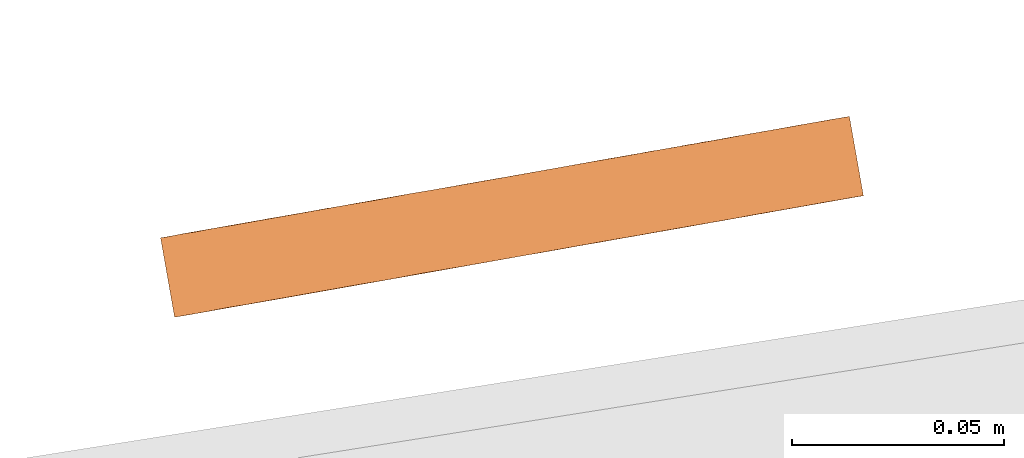
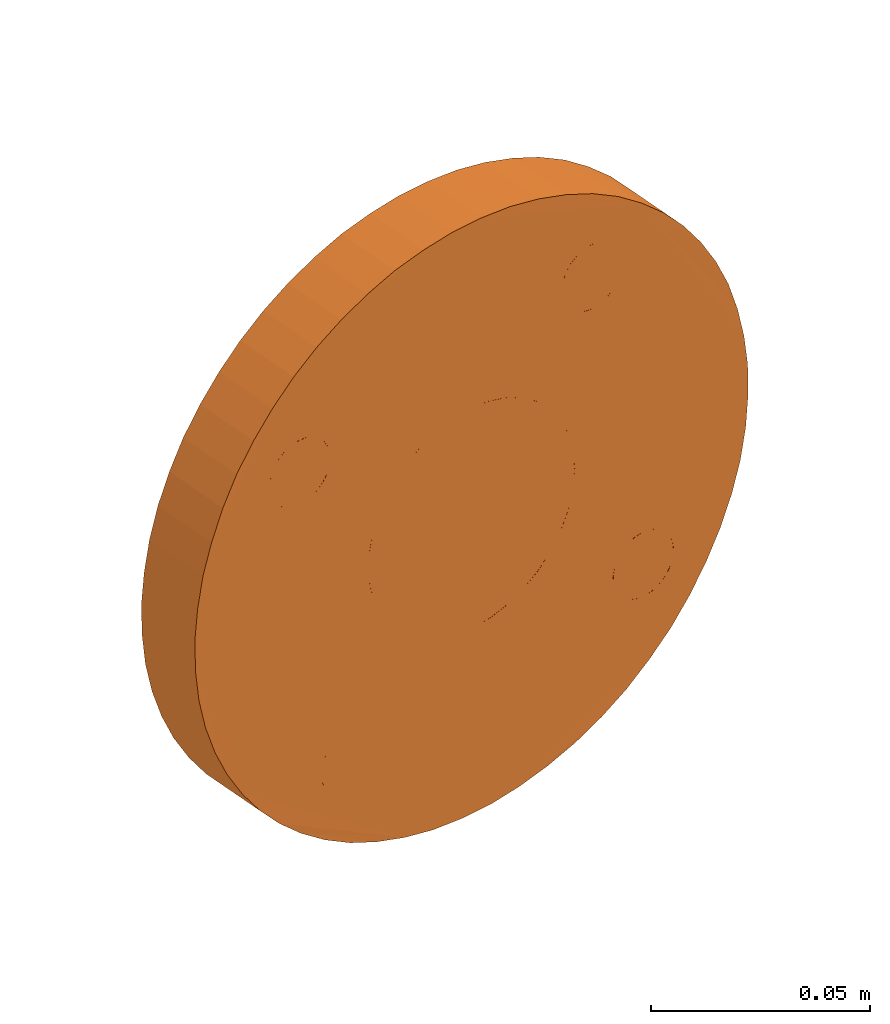
# One storey, part 89 of 126: 1 proxy.
"""IFC2X3 building model written with IfcOpenShell, lengths in millimetres."""

from ifc_helpers import new_model, si_unit, origin, origin_with_axes, place, context, project, spatial, faceted_brep, material, element, save


model = new_model("IFC2X3")

# Units and contexts
context_of_model_1 = context(None, 3, precision=0.1, world=origin())
context_of_model_2 = context(None, 3, precision=0.1, world=origin())
ifc_project = project(units=[si_unit("LENGTHUNIT", "METRE", prefix="MILLI"), si_unit("AREAUNIT", "SQUARE_METRE", prefix="CENTI"), si_unit("VOLUMEUNIT", "CUBIC_METRE", prefix="CENTI"), si_unit("MASSUNIT", "GRAM", prefix="KILO")], contexts=[context_of_model_1, context_of_model_2])

# Site, building, storey
site_placement = place(None, origin_with_axes())
site = spatial("IfcSite", under=ifc_project, at=site_placement, CompositionType="ELEMENT")
building_placement = place(site_placement, origin_with_axes())
building = spatial("IfcBuilding", under=site, at=building_placement, CompositionType="ELEMENT")
storey_placement = place(building_placement, origin_with_axes())
storey = spatial("IfcBuildingStorey", under=building, at=storey_placement, CompositionType="ELEMENT")

# Proxy
ifc_material = material(Name="STAHL")
proxy_placement = place(storey_placement, origin_with_axes())
element("IfcBuildingElementProxy", 1, at=proxy_placement, inside=storey, material=ifc_material, Name="profile", context=context_of_model_2, shape_type="Brep", body=[
    faceted_brep([(6584.0, 15901.2, 1518.5), (6592.2, 15902.6, 1516.0), (6595.5, 15883.9, 1516.0), (6587.3, 15882.5, 1518.5), (6576.2, 15899.8, 1521.8), (6579.5, 15881.1, 1521.8), (6692.9, 15920.4, 1601.8), (6691.8, 15920.2, 1610.3), (6695.1, 15901.5, 1610.3), (6696.2, 15901.7, 1601.8), (6568.8, 15898.5, 1526.0), (6572.1, 15879.8, 1526.0), (6696.3, 15901.7, 1593.1), (6693.0, 15920.4, 1593.1), (6695.6, 15901.6, 1584.5), (6692.3, 15920.3, 1584.5), (6561.8, 15897.3, 1531.0), (6565.1, 15878.6, 1531.0), (6694.0, 15901.3, 1576.0), (6690.7, 15920.0, 1576.0), (6555.4, 15896.2, 1536.7), (6558.7, 15877.4, 1536.7), (6691.5, 15900.9, 1567.8), (6688.2, 15919.6, 1567.8), (6549.6, 15895.1, 1543.0), (6552.9, 15876.4, 1543.0), (6688.1, 15900.3, 1559.8), (6684.8, 15919.0, 1559.8), (6544.5, 15894.2, 1549.9), (6547.8, 15875.5, 1549.9), (6684.0, 15899.6, 1552.3), (6680.7, 15918.3, 1552.3), (6540.1, 15893.5, 1557.3), (6543.4, 15874.8, 1557.3), (6679.1, 15898.7, 1545.2), (6675.8, 15917.4, 1545.2), (6536.5, 15892.8, 1565.1), (6539.8, 15874.1, 1565.1), (6533.7, 15892.3, 1573.3), (6537.0, 15873.6, 1573.3), (6535.1, 15873.3, 1581.7), (6531.8, 15892.0, 1581.7), (6670.3, 15916.4, 1538.7), (6673.6, 15897.7, 1538.7), (6664.0, 15915.3, 1532.8), (6667.3, 15896.6, 1532.8), (6657.3, 15914.1, 1527.6), (6660.6, 15895.4, 1527.6), (6650.0, 15912.8, 1523.2), (6653.3, 15894.1, 1523.2), (6642.3, 15911.5, 1519.5), (6645.6, 15892.8, 1519.5), (6634.2, 15910.1, 1516.7), (6637.5, 15891.4, 1516.7), (6625.9, 15908.6, 1514.8), (6629.2, 15889.9, 1514.8), (6617.5, 15907.1, 1513.7), (6620.8, 15888.4, 1513.7), (6609.0, 15905.6, 1513.6), (6612.3, 15886.9, 1513.6), (6600.5, 15904.1, 1514.3), (6603.8, 15885.4, 1514.3), (6642.1, 15911.5, 1596.0), (6645.4, 15892.7, 1596.0), (6644.9, 15892.7, 1601.3), (6641.6, 15911.4, 1601.3), (6641.6, 15911.4, 1590.7), (6644.9, 15892.7, 1590.7), (6640.3, 15911.1, 1585.5), (6643.6, 15892.4, 1585.5), (6638.0, 15910.7, 1580.6), (6641.3, 15892.0, 1580.6), (6635.0, 15910.2, 1576.2), (6638.3, 15891.5, 1576.2), (6631.3, 15909.5, 1572.4), (6634.6, 15890.8, 1572.4), (6627.0, 15908.8, 1569.4), (6630.3, 15890.1, 1569.4), (6622.2, 15907.9, 1567.1), (6625.5, 15889.2, 1567.1), (6617.1, 15907.0, 1565.7), (6620.4, 15888.3, 1565.7), (6611.8, 15906.1, 1565.3), (6615.1, 15887.4, 1565.3), (6606.6, 15905.2, 1565.7), (6609.9, 15886.5, 1565.7), (6601.5, 15904.3, 1567.1), (6604.8, 15885.6, 1567.1), (6596.7, 15903.4, 1569.4), (6600.0, 15884.7, 1569.4), (6592.4, 15902.7, 1572.4), (6595.7, 15884.0, 1572.4), (6588.6, 15902.0, 1576.2), (6591.9, 15883.3, 1576.2), (6585.6, 15901.5, 1580.6), (6588.9, 15882.8, 1580.6), (6583.4, 15901.1, 1585.5), (6586.7, 15882.4, 1585.5), (6582.0, 15900.9, 1590.7), (6585.3, 15882.1, 1590.7), (6656.0, 15913.9, 1646.6), (6659.3, 15895.2, 1646.6), (6659.2, 15895.2, 1648.8), (6655.9, 15913.9, 1648.8), (6655.6, 15913.8, 1644.5), (6658.9, 15895.1, 1644.5), (6654.7, 15913.7, 1642.5), (6658.0, 15895.0, 1642.5), (6653.3, 15913.4, 1640.8), (6656.6, 15894.7, 1640.8), (6651.7, 15913.1, 1639.5), (6655.0, 15894.4, 1639.5), (6649.7, 15912.8, 1638.6), (6653.0, 15894.1, 1638.6), (6647.6, 15912.4, 1638.2), (6650.9, 15893.7, 1638.2), (6645.5, 15912.0, 1638.4), (6648.8, 15893.3, 1638.4), (6643.4, 15911.7, 1639.0), (6646.7, 15893.0, 1639.0), (6641.6, 15911.4, 1640.1), (6644.9, 15892.7, 1640.1), (6640.1, 15911.1, 1641.7), (6643.4, 15892.4, 1641.7), (6639.0, 15910.9, 1643.6), (6642.3, 15892.2, 1643.6), (6638.4, 15910.8, 1645.6), (6641.7, 15892.1, 1645.6), (6585.2, 15901.4, 1546.4), (6585.4, 15901.4, 1544.2), (6588.7, 15882.7, 1544.2), (6588.5, 15882.7, 1546.4), (6585.0, 15901.4, 1542.1), (6588.3, 15882.7, 1542.1), (6584.1, 15901.2, 1540.1), (6587.4, 15882.5, 1540.1), (6582.7, 15901.0, 1538.4), (6586.0, 15882.3, 1538.4), (6581.1, 15900.7, 1537.1), (6584.4, 15882.0, 1537.1), (6579.1, 15900.3, 1536.2), (6582.4, 15881.6, 1536.2), (6577.0, 15900.0, 1535.8), (6580.3, 15881.3, 1535.8), (6574.9, 15899.6, 1536.0), (6578.2, 15880.9, 1536.0), (6572.8, 15899.2, 1536.6), (6576.1, 15880.5, 1536.6), (6571.0, 15898.9, 1537.8), (6574.3, 15880.2, 1537.8), (6569.5, 15898.7, 1539.3), (6572.8, 15879.9, 1539.3), (6568.4, 15898.5, 1541.2), (6571.7, 15879.7, 1541.2), (6567.8, 15898.3, 1543.2), (6571.1, 15879.6, 1543.2), (6671.0, 15916.5, 1561.7), (6671.1, 15916.6, 1559.5), (6674.4, 15897.9, 1559.5), (6674.3, 15897.8, 1561.7), (6670.7, 15916.5, 1557.4), (6674.0, 15897.8, 1557.4), (6669.8, 15916.3, 1555.4), (6673.1, 15897.6, 1555.4), (6668.5, 15916.1, 1553.7), (6671.8, 15897.4, 1553.7), (6666.8, 15915.8, 1552.4), (6670.1, 15897.1, 1552.4), (6664.8, 15915.5, 1551.5), (6668.1, 15896.7, 1551.5), (6662.7, 15915.1, 1551.2), (6666.0, 15896.4, 1551.2), (6660.6, 15914.7, 1551.3), (6663.9, 15896.0, 1551.3), (6658.5, 15914.4, 1552.0), (6661.8, 15895.6, 1552.0), (6656.7, 15914.0, 1553.1), (6660.0, 15895.3, 1553.1), (6655.2, 15913.8, 1554.6), (6658.5, 15895.1, 1554.6), (6654.1, 15913.6, 1556.5), (6657.4, 15894.9, 1556.5), (6653.5, 15913.5, 1558.6), (6656.8, 15894.8, 1558.6), (6570.1, 15898.8, 1633.4), (6570.2, 15898.8, 1631.2), (6573.5, 15880.1, 1631.2), (6573.4, 15880.1, 1633.4), (6569.8, 15898.7, 1629.1), (6573.1, 15880.0, 1629.1), (6569.0, 15898.6, 1627.1), (6572.3, 15879.8, 1627.1), (6567.6, 15898.3, 1625.4), (6570.9, 15879.6, 1625.4), (6565.9, 15898.0, 1624.1), (6569.2, 15879.3, 1624.1), (6564.0, 15897.7, 1623.2), (6567.3, 15879.0, 1623.2), (6561.9, 15897.3, 1622.9), (6565.2, 15878.6, 1622.9), (6559.7, 15896.9, 1623.0), (6563.0, 15878.2, 1623.0), (6557.7, 15896.6, 1623.7), (6561.0, 15877.9, 1623.7), (6555.9, 15896.3, 1624.8), (6559.2, 15877.5, 1624.8), (6554.4, 15896.0, 1626.3), (6557.7, 15877.3, 1626.3), (6553.3, 15895.8, 1628.2), (6556.6, 15877.1, 1628.2), (6552.7, 15895.7, 1630.3), (6556.0, 15877.0, 1630.3), (6552.6, 15895.7, 1632.5), (6555.9, 15877.0, 1632.5), (6553.0, 15895.7, 1634.6), (6556.3, 15877.0, 1634.6), (6553.8, 15895.9, 1636.6), (6557.1, 15877.2, 1636.6), (6555.2, 15896.1, 1638.3), (6558.5, 15877.4, 1638.3), (6556.9, 15896.4, 1639.6), (6560.2, 15877.7, 1639.6), (6558.8, 15896.8, 1640.5), (6562.1, 15878.1, 1640.5), (6560.9, 15897.1, 1640.8), (6564.2, 15878.4, 1640.8), (6563.1, 15897.5, 1640.7), (6566.4, 15878.8, 1640.7), (6565.1, 15897.9, 1640.0), (6568.4, 15879.2, 1640.0), (6566.9, 15898.2, 1638.9), (6570.2, 15879.5, 1638.9), (6568.4, 15898.5, 1637.4), (6571.7, 15879.7, 1637.4), (6569.5, 15898.7, 1635.5), (6572.8, 15879.9, 1635.5), (6653.4, 15913.4, 1560.8), (6656.7, 15894.7, 1560.8), (6653.8, 15913.5, 1562.9), (6657.1, 15894.8, 1562.9), (6654.7, 15913.7, 1564.9), (6658.0, 15895.0, 1564.9), (6656.0, 15913.9, 1566.6), (6659.3, 15895.2, 1566.6), (6657.7, 15914.2, 1567.9), (6661.0, 15895.5, 1567.9), (6659.7, 15914.5, 1568.8), (6663.0, 15895.8, 1568.8), (6661.8, 15914.9, 1569.1), (6665.1, 15896.2, 1569.1), (6663.9, 15915.3, 1569.0), (6667.2, 15896.6, 1569.0), (6665.9, 15915.7, 1568.3), (6669.2, 15896.9, 1568.3), (6667.8, 15916.0, 1567.2), (6671.1, 15897.3, 1567.2), (6669.3, 15916.2, 1565.7), (6672.6, 15897.5, 1565.7), (6670.3, 15916.4, 1563.8), (6673.6, 15897.7, 1563.8), (6567.7, 15898.3, 1545.4), (6571.0, 15879.6, 1545.4), (6568.1, 15898.4, 1547.5), (6571.4, 15879.7, 1547.5), (6569.0, 15898.6, 1549.5), (6572.3, 15879.8, 1549.5), (6570.3, 15898.8, 1551.2), (6573.6, 15880.1, 1551.2), (6572.0, 15899.1, 1552.5), (6575.3, 15880.4, 1552.5), (6573.9, 15899.4, 1553.4), (6577.2, 15880.7, 1553.4), (6576.0, 15899.8, 1553.8), (6579.3, 15881.1, 1553.8), (6578.2, 15900.2, 1553.6), (6581.5, 15881.5, 1553.6), (6580.2, 15900.5, 1553.0), (6583.5, 15881.8, 1553.0), (6582.0, 15900.9, 1551.9), (6585.3, 15882.1, 1551.9), (6583.5, 15901.1, 1550.3), (6586.8, 15882.4, 1550.3), (6584.6, 15901.3, 1548.4), (6587.9, 15882.6, 1548.4), (6638.3, 15910.8, 1647.8), (6641.6, 15892.1, 1647.8), (6638.7, 15910.8, 1649.9), (6642.0, 15892.1, 1649.9), (6639.6, 15911.0, 1651.9), (6642.9, 15892.3, 1651.9), (6640.9, 15911.2, 1653.6), (6644.2, 15892.5, 1653.6), (6642.6, 15911.5, 1654.9), (6645.9, 15892.8, 1654.9), (6644.5, 15911.9, 1655.8), (6647.8, 15893.2, 1655.8), (6646.6, 15912.3, 1656.2), (6649.9, 15893.5, 1656.2), (6648.8, 15912.6, 1656.0), (6652.1, 15893.9, 1656.0), (6650.8, 15913.0, 1655.4), (6654.1, 15894.3, 1655.4), (6652.6, 15913.3, 1654.2), (6655.9, 15894.6, 1654.2), (6654.1, 15913.6, 1652.7), (6657.4, 15894.9, 1652.7), (6655.2, 15913.8, 1650.8), (6658.5, 15895.1, 1650.8), (6530.6, 15891.8, 1598.9), (6531.4, 15891.9, 1607.5), (6533.0, 15892.2, 1616.0), (6535.5, 15892.7, 1624.2), (6538.8, 15893.2, 1632.2), (6542.9, 15894.0, 1639.7), (6547.8, 15894.8, 1646.8), (6553.4, 15895.8, 1653.3), (6559.6, 15896.9, 1659.2), (6566.4, 15898.1, 1664.4), (6573.7, 15899.4, 1668.8), (6581.4, 15900.7, 1672.5), (6589.4, 15902.2, 1675.3), (6597.7, 15903.6, 1677.2), (6606.2, 15905.1, 1678.3), (6614.7, 15906.6, 1678.4), (6623.1, 15908.1, 1677.7), (6631.5, 15909.6, 1676.0), (6639.6, 15911.0, 1673.5), (6647.4, 15912.4, 1670.2), (6654.9, 15913.7, 1666.0), (6661.8, 15914.9, 1661.0), (6668.3, 15916.1, 1655.3), (6674.1, 15917.1, 1649.0), (6679.2, 15918.0, 1642.1), (6683.6, 15918.8, 1634.7), (6687.2, 15919.4, 1626.9), (6689.9, 15919.9, 1618.7), (6640.3, 15911.1, 1606.5), (6638.0, 15910.7, 1611.4), (6635.0, 15910.2, 1615.8), (6631.3, 15909.5, 1619.6), (6627.0, 15908.8, 1622.6), (6622.2, 15907.9, 1624.9), (6617.1, 15907.0, 1626.3), (6611.8, 15906.1, 1626.8), (6606.6, 15905.2, 1626.3), (6601.5, 15904.3, 1624.9), (6596.7, 15903.4, 1622.6), (6592.4, 15902.7, 1619.6), (6588.6, 15902.0, 1615.8), (6585.6, 15901.5, 1611.4), (6583.4, 15901.1, 1606.5), (6582.0, 15900.9, 1601.3), (6581.5, 15900.8, 1596.0), (6530.8, 15891.8, 1590.2), (6533.9, 15873.1, 1598.9), (6534.1, 15873.1, 1590.2), (6693.2, 15901.2, 1618.7), (6690.5, 15900.7, 1626.9), (6686.9, 15900.1, 1634.7), (6682.5, 15899.3, 1642.1), (6615.1, 15887.4, 1626.8), (6620.4, 15888.3, 1626.3), (6625.5, 15889.2, 1624.9), (6630.3, 15890.1, 1622.6), (6634.6, 15890.8, 1619.6), (6638.3, 15891.5, 1615.8), (6641.3, 15892.0, 1611.4), (6643.6, 15892.4, 1606.5), (6584.8, 15882.1, 1596.0), (6585.3, 15882.1, 1601.3), (6586.7, 15882.4, 1606.5), (6588.9, 15882.8, 1611.4), (6591.9, 15883.3, 1615.8), (6595.7, 15884.0, 1619.6), (6600.0, 15884.7, 1622.6), (6604.8, 15885.6, 1624.9), (6609.9, 15886.5, 1626.3), (6677.4, 15898.4, 1649.0), (6671.6, 15897.4, 1655.3), (6665.1, 15896.2, 1661.0), (6658.2, 15895.0, 1666.0), (6650.7, 15893.7, 1670.2), (6642.9, 15892.3, 1673.5), (6634.8, 15890.9, 1676.0), (6626.4, 15889.4, 1677.7), (6618.0, 15887.9, 1678.4), (6609.5, 15886.4, 1678.3), (6601.0, 15884.9, 1677.2), (6592.7, 15883.5, 1675.3), (6584.7, 15882.0, 1672.5), (6577.0, 15880.7, 1668.8), (6569.7, 15879.4, 1664.4), (6562.9, 15878.2, 1659.2), (6556.7, 15877.1, 1653.3), (6551.1, 15876.1, 1646.8), (6546.2, 15875.3, 1639.7), (6542.1, 15874.5, 1632.2), (6538.8, 15873.9, 1624.2), (6536.3, 15873.5, 1616.0), (6534.7, 15873.2, 1607.5)], [[[0, 1, 2, 3]], [[4, 0, 3, 5]], [[6, 7, 8, 9]], [[10, 4, 5, 11]], [[6, 9, 12, 13]], [[13, 12, 14, 15]], [[16, 10, 11, 17]], [[15, 14, 18, 19]], [[20, 16, 17, 21]], [[19, 18, 22, 23]], [[24, 20, 21, 25]], [[23, 22, 26, 27]], [[28, 24, 25, 29]], [[27, 26, 30, 31]], [[32, 28, 29, 33]], [[31, 30, 34, 35]], [[36, 32, 33, 37]], [[38, 36, 37, 39]], [[38, 39, 40, 41]], [[42, 35, 34, 43]], [[44, 42, 43, 45]], [[46, 44, 45, 47]], [[48, 46, 47, 49]], [[50, 48, 49, 51]], [[52, 50, 51, 53]], [[54, 52, 53, 55]], [[56, 54, 55, 57]], [[58, 56, 57, 59]], [[60, 58, 59, 61]], [[1, 60, 61, 2]], [[62, 63, 64, 65]], [[66, 67, 63, 62]], [[68, 69, 67, 66]], [[70, 71, 69, 68]], [[72, 73, 71, 70]], [[74, 75, 73, 72]], [[76, 77, 75, 74]], [[78, 79, 77, 76]], [[80, 81, 79, 78]], [[82, 83, 81, 80]], [[84, 85, 83, 82]], [[86, 87, 85, 84]], [[88, 89, 87, 86]], [[90, 91, 89, 88]], [[92, 93, 91, 90]], [[94, 95, 93, 92]], [[96, 97, 95, 94]], [[98, 99, 97, 96]], [[100, 101, 102, 103]], [[104, 105, 101, 100]], [[106, 107, 105, 104]], [[108, 109, 107, 106]], [[110, 111, 109, 108]], [[112, 113, 111, 110]], [[114, 115, 113, 112]], [[116, 117, 115, 114]], [[118, 119, 117, 116]], [[120, 121, 119, 118]], [[122, 123, 121, 120]], [[124, 125, 123, 122]], [[126, 127, 125, 124]], [[128, 129, 130, 131]], [[129, 132, 133, 130]], [[132, 134, 135, 133]], [[134, 136, 137, 135]], [[136, 138, 139, 137]], [[138, 140, 141, 139]], [[140, 142, 143, 141]], [[142, 144, 145, 143]], [[144, 146, 147, 145]], [[146, 148, 149, 147]], [[148, 150, 151, 149]], [[150, 152, 153, 151]], [[152, 154, 155, 153]], [[156, 157, 158, 159]], [[157, 160, 161, 158]], [[160, 162, 163, 161]], [[162, 164, 165, 163]], [[164, 166, 167, 165]], [[166, 168, 169, 167]], [[168, 170, 171, 169]], [[170, 172, 173, 171]], [[172, 174, 175, 173]], [[174, 176, 177, 175]], [[176, 178, 179, 177]], [[178, 180, 181, 179]], [[180, 182, 183, 181]], [[184, 185, 186, 187]], [[185, 188, 189, 186]], [[188, 190, 191, 189]], [[190, 192, 193, 191]], [[192, 194, 195, 193]], [[194, 196, 197, 195]], [[196, 198, 199, 197]], [[198, 200, 201, 199]], [[200, 202, 203, 201]], [[202, 204, 205, 203]], [[204, 206, 207, 205]], [[206, 208, 209, 207]], [[208, 210, 211, 209]], [[212, 213, 211, 210]], [[212, 214, 215, 213]], [[214, 216, 217, 215]], [[216, 218, 219, 217]], [[218, 220, 221, 219]], [[220, 222, 223, 221]], [[222, 224, 225, 223]], [[224, 226, 227, 225]], [[226, 228, 229, 227]], [[228, 230, 231, 229]], [[230, 232, 233, 231]], [[232, 234, 235, 233]], [[234, 184, 187, 235]], [[236, 237, 183, 182]], [[236, 238, 239, 237]], [[238, 240, 241, 239]], [[240, 242, 243, 241]], [[242, 244, 245, 243]], [[244, 246, 247, 245]], [[246, 248, 249, 247]], [[248, 250, 251, 249]], [[250, 252, 253, 251]], [[252, 254, 255, 253]], [[254, 256, 257, 255]], [[256, 258, 259, 257]], [[258, 156, 159, 259]], [[260, 261, 155, 154]], [[262, 263, 261, 260]], [[264, 265, 263, 262]], [[266, 267, 265, 264]], [[268, 269, 267, 266]], [[270, 271, 269, 268]], [[272, 273, 271, 270]], [[274, 275, 273, 272]], [[276, 277, 275, 274]], [[278, 279, 277, 276]], [[280, 281, 279, 278]], [[282, 283, 281, 280]], [[128, 131, 283, 282]], [[126, 284, 285, 127]], [[284, 286, 287, 285]], [[286, 288, 289, 287]], [[288, 290, 291, 289]], [[290, 292, 293, 291]], [[292, 294, 295, 293]], [[294, 296, 297, 295]], [[296, 298, 299, 297]], [[298, 300, 301, 299]], [[300, 302, 303, 301]], [[302, 304, 305, 303]], [[304, 306, 307, 305]], [[306, 103, 102, 307]], [[308, 309, 310, 311, 312, 313, 314, 315, 316, 317, 318, 319, 320, 321, 322, 323, 324, 325, 326, 327, 328, 329, 330, 331, 332, 333, 334, 335, 7, 6, 13, 15, 19, 23, 27, 31, 35, 42, 44, 46, 48, 50, 52, 54, 56, 58, 60, 132, 129, 128, 282, 280, 278, 276, 274, 272, 270, 268, 96, 94, 92, 90, 88, 86, 84, 82, 80, 78, 76, 74, 72, 70, 68, 66, 62, 250, 248, 246, 244, 242, 240, 238, 236, 182, 180, 178, 176, 174, 172, 170, 168, 166, 164, 162, 160, 157, 156, 258, 256, 254, 252, 250, 62, 65, 336, 337, 338, 339, 340, 341, 342, 343, 284, 126, 124, 122, 120, 118, 116, 114, 112, 110, 108, 106, 104, 100, 103, 306, 304, 302, 300, 298, 296, 294, 292, 290, 288, 286, 284, 343, 344, 345, 346, 347, 348, 349, 350, 351, 352, 200, 198, 196, 194, 192, 190, 188, 185, 184, 234, 232, 230, 228, 226, 224, 222, 220, 218, 216, 214, 212, 210, 208, 206, 204, 202, 200, 352, 98, 96, 268, 266, 264, 262, 260, 154, 152, 150, 148, 146, 144, 142, 140, 138, 136, 134, 132, 60, 1, 0, 4, 10, 16, 20, 24, 28, 32, 36, 38, 41, 353]], [[354, 355, 40, 39, 37, 33, 29, 25, 21, 17, 11, 5, 3, 2, 61, 59, 57, 55, 53, 51, 49, 47, 45, 43, 34, 30, 26, 22, 18, 14, 12, 9, 8, 356, 357, 358, 359, 105, 107, 109, 111, 113, 115, 117, 119, 121, 123, 125, 127, 285, 360, 361, 362, 363, 364, 365, 366, 367, 64, 63, 67, 69, 71, 73, 75, 77, 79, 181, 183, 237, 239, 241, 243, 245, 247, 249, 251, 253, 255, 257, 259, 159, 158, 161, 163, 165, 167, 169, 171, 173, 175, 177, 179, 181, 79, 81, 83, 85, 87, 89, 91, 93, 95, 97, 269, 271, 273, 275, 277, 279, 281, 283, 131, 130, 133, 135, 137, 139, 141, 143, 145, 147, 149, 151, 153, 155, 261, 263, 265, 267, 269, 97, 99, 368, 369, 370, 371, 372, 373, 374, 375, 235, 187, 186, 189, 191, 193, 195, 197, 199, 201, 203, 205, 207, 209, 211, 213, 215, 217, 219, 221, 223, 225, 227, 229, 231, 233, 235, 375, 376, 360, 285, 287, 289, 291, 293, 295, 297, 299, 301, 303, 305, 307, 102, 101, 105, 359, 377, 378, 379, 380, 381, 382, 383, 384, 385, 386, 387, 388, 389, 390, 391, 392, 393, 394, 395, 396, 397, 398, 399]], [[98, 352, 368, 99]], [[352, 351, 369, 368]], [[351, 350, 370, 369]], [[350, 349, 371, 370]], [[349, 348, 372, 371]], [[348, 347, 373, 372]], [[347, 346, 374, 373]], [[346, 345, 375, 374]], [[345, 344, 376, 375]], [[344, 343, 360, 376]], [[343, 342, 361, 360]], [[342, 341, 362, 361]], [[341, 340, 363, 362]], [[340, 339, 364, 363]], [[339, 338, 365, 364]], [[338, 337, 366, 365]], [[337, 336, 367, 366]], [[336, 65, 64, 367]], [[326, 382, 381, 327]], [[327, 381, 380, 328]], [[328, 380, 379, 329]], [[353, 41, 40, 355]], [[329, 379, 378, 330]], [[308, 353, 355, 354]], [[330, 378, 377, 331]], [[309, 308, 354, 399]], [[331, 377, 359, 332]], [[310, 309, 399, 398]], [[332, 359, 358, 333]], [[311, 310, 398, 397]], [[333, 358, 357, 334]], [[334, 357, 356, 335]], [[312, 311, 397, 396]], [[335, 356, 8, 7]], [[313, 312, 396, 395]], [[314, 313, 395, 394]], [[315, 314, 394, 393]], [[316, 315, 393, 392]], [[316, 392, 391, 317]], [[317, 391, 390, 318]], [[318, 390, 389, 319]], [[319, 389, 388, 320]], [[320, 388, 387, 321]], [[321, 387, 386, 322]], [[322, 386, 385, 323]], [[323, 385, 384, 324]], [[324, 384, 383, 325]], [[325, 383, 382, 326]]]),
])

save(model, "model.ifc")
